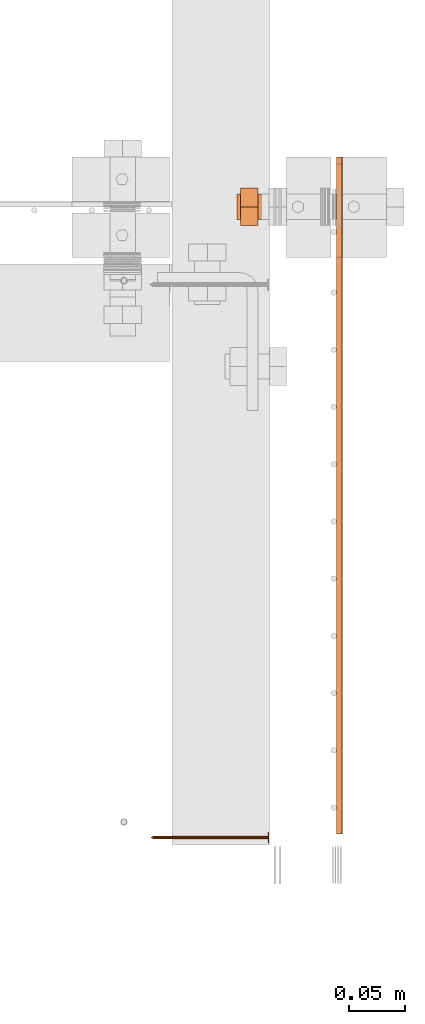
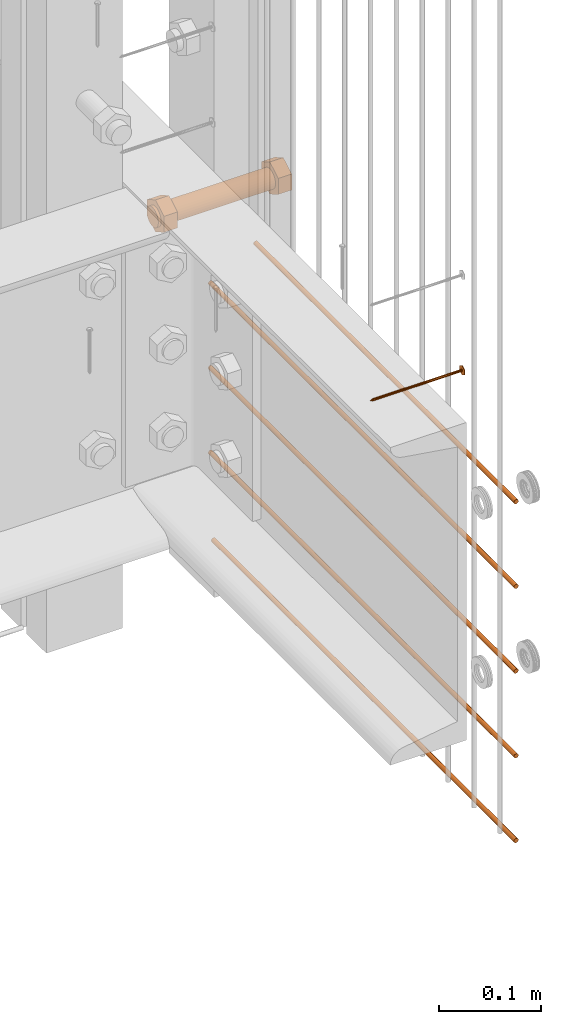
# One storey, part 21 of 44: 7 proxies.
"""IFC4 building model written with IfcOpenShell, lengths in feet."""

from ifc_helpers import new_model, entity, si_unit, converted_unit, derived_unit, direction, frame, frame_2d, origin, origin_2d_with_axis, place, context, subcontext, project, spatial, polyline, circle, outline, extrude, source, transform, mapped, material, type_object, type_shapes, element, save


model = new_model("IFC4")

# Units and contexts
model_context = context("Model", 3, precision=0.0001, world=origin(), true_north=direction((6.12303176911189e-17, 1.0)))
body_context = subcontext(model_context, "Body", "Model", "MODEL_VIEW")
ifc_project = project(units=[converted_unit("LENGTHUNIT", "FOOT", entity("IfcRatioMeasure", 0.3048), si_unit("LENGTHUNIT", "METRE"), dimensions=[1, 0, 0, 0, 0, 0, 0]), converted_unit("AREAUNIT", "SQUARE FOOT", entity("IfcRatioMeasure", 0.09290304), si_unit("AREAUNIT", "SQUARE_METRE"), dimensions=[2, 0, 0, 0, 0, 0, 0]), converted_unit("VOLUMEUNIT", "CUBIC FOOT", entity("IfcRatioMeasure", 0.028316846592), si_unit("VOLUMEUNIT", "CUBIC_METRE"), dimensions=[3, 0, 0, 0, 0, 0, 0]), converted_unit("PLANEANGLEUNIT", "DEGREE", entity("IfcRatioMeasure", 0.0174532925199433), si_unit("PLANEANGLEUNIT", "RADIAN"), dimensions=[0, 0, 0, 0, 0, 0, 0]), si_unit("MASSUNIT", "GRAM", prefix="KILO"), derived_unit("MASSDENSITYUNIT", [(si_unit("MASSUNIT", "GRAM", prefix="KILO"), 1), (si_unit("LENGTHUNIT", "METRE"), -3)]), derived_unit("MOMENTOFINERTIAUNIT", [(si_unit("LENGTHUNIT", "METRE"), 4)]), si_unit("TIMEUNIT", "SECOND"), si_unit("FREQUENCYUNIT", "HERTZ"), si_unit("THERMODYNAMICTEMPERATUREUNIT", "DEGREE_CELSIUS"), derived_unit("THERMALTRANSMITTANCEUNIT", [(si_unit("MASSUNIT", "GRAM", prefix="KILO"), 1), (si_unit("THERMODYNAMICTEMPERATUREUNIT", "KELVIN"), -1), (si_unit("TIMEUNIT", "SECOND"), -3)]), derived_unit("VOLUMETRICFLOWRATEUNIT", [(si_unit("LENGTHUNIT", "METRE"), 3), (si_unit("TIMEUNIT", "SECOND"), -1)]), si_unit("ELECTRICCURRENTUNIT", "AMPERE"), si_unit("ELECTRICVOLTAGEUNIT", "VOLT"), si_unit("POWERUNIT", "WATT"), si_unit("FORCEUNIT", "NEWTON"), si_unit("ILLUMINANCEUNIT", "LUX"), si_unit("LUMINOUSFLUXUNIT", "LUMEN"), si_unit("LUMINOUSINTENSITYUNIT", "CANDELA"), derived_unit("USERDEFINED", [(si_unit("MASSUNIT", "GRAM", prefix="KILO"), -1), (si_unit("LENGTHUNIT", "METRE"), -2), (si_unit("TIMEUNIT", "SECOND"), 3), (si_unit("LUMINOUSFLUXUNIT", "LUMEN"), 1)]), derived_unit("LINEARVELOCITYUNIT", [(si_unit("LENGTHUNIT", "METRE"), 1), (si_unit("TIMEUNIT", "SECOND"), -1)]), si_unit("PRESSUREUNIT", "PASCAL"), derived_unit("USERDEFINED", [(si_unit("LENGTHUNIT", "METRE"), -2), (si_unit("MASSUNIT", "GRAM", prefix="KILO"), 1), (si_unit("TIMEUNIT", "SECOND"), -2)]), derived_unit("LINEARFORCEUNIT", [(si_unit("MASSUNIT", "GRAM", prefix="KILO"), 1), (si_unit("LENGTHUNIT", "METRE"), 1), (si_unit("TIMEUNIT", "SECOND"), -2), (si_unit("LENGTHUNIT", "METRE"), -1)]), derived_unit("PLANARFORCEUNIT", [(si_unit("MASSUNIT", "GRAM", prefix="KILO"), 1), (si_unit("LENGTHUNIT", "METRE"), 1), (si_unit("TIMEUNIT", "SECOND"), -2), (si_unit("LENGTHUNIT", "METRE"), -2)])], contexts=[model_context])

# Site, building, storey
site_placement = place(None, origin())
site = spatial("IfcSite", under=ifc_project, at=site_placement, CompositionType="ELEMENT")
building_placement = place(site_placement, origin())
building = spatial("IfcBuilding", under=site, at=building_placement, CompositionType="ELEMENT")
storey_placement = place(building_placement, origin())
storey = spatial("IfcBuildingStorey", under=building, at=storey_placement, CompositionType="ELEMENT", Elevation=0.0)

# Proxies
ifc_material_1 = material(Category="Materials")
building_element_proxy_type_1 = type_object("IfcBuildingElementProxyType", Name="RAILING 14:RAILING 3", PredefinedType="NOTDEFINED", material=ifc_material_1)
shared_shape_1 = source(origin(), body_context, "Body", "SweptSolid", [
    extrude(circle(Radius=0.00833333333333333, at=origin_2d_with_axis()), frame((0.013567166128496, 0.0, 0.0135671661283361), z_axis=(0.0, 1.0, 0.0), x_axis=(1.0, 0.0, 0.0)), (0.0, 0.0, 1.0), 1.67905011872063),
])
type_shapes(building_element_proxy_type_1, [shared_shape_1])
proxy_1_placement = place(storey_placement, frame((1494.48288887973, 3.07882213648387, 9.50518283387163)))
element("IfcBuildingElementProxy", 1, at=proxy_1_placement, inside=storey, type_object=building_element_proxy_type_1, material=ifc_material_1, Name="RAILING 14:RAILING 3", ObjectType="RAILING 14:RAILING 3", PredefinedType="NOTDEFINED", context=body_context, shape_type="MappedRepresentation", body=[
    mapped(shared_shape_1, transform((0.0, 0.0, 0.0), scale=1.0)),
])
building_element_proxy_type_2 = type_object("IfcBuildingElementProxyType", Name="RAILING 15:RAILING 3", PredefinedType="NOTDEFINED", material=ifc_material_1)
shared_shape_2 = source(origin(), body_context, "Body", "SweptSolid", [
    extrude(circle(Radius=0.00833333333333333, at=origin_2d_with_axis()), frame((0.013567166128496, 0.0, 0.0135671661283361), z_axis=(0.0, 1.0, 0.0), x_axis=(1.0, 0.0, 0.0)), (0.0, 0.0, 1.0), 1.97071678538729),
])
type_shapes(building_element_proxy_type_2, [shared_shape_2])
proxy_2_placement = place(storey_placement, frame((1494.48288887973, 3.07882213648387, 9.1718495005383)))
element("IfcBuildingElementProxy", 2, at=proxy_2_placement, inside=storey, type_object=building_element_proxy_type_2, material=ifc_material_1, Name="RAILING 15:RAILING 3", ObjectType="RAILING 15:RAILING 3", PredefinedType="NOTDEFINED", context=body_context, shape_type="MappedRepresentation", body=[
    mapped(shared_shape_2, transform((0.0, 0.0, 0.0), scale=1.0)),
])
building_element_proxy_type_3 = type_object("IfcBuildingElementProxyType", Name="RAILING 16:RAILING 3", PredefinedType="NOTDEFINED", material=ifc_material_1)
shared_shape_3 = source(origin(), body_context, "Body", "SweptSolid", [
    extrude(circle(Radius=0.00833333333333333, at=origin_2d_with_axis()), frame((0.013567166128496, 0.0, 0.0135671661283361), z_axis=(0.0, 1.0, 0.0), x_axis=(1.0, 0.0, 0.0)), (0.0, 0.0, 1.0), 1.97071678538729),
])
type_shapes(building_element_proxy_type_3, [shared_shape_3])
proxy_3_placement = place(storey_placement, frame((1494.48288887973, 3.07882213648387, 8.83851616720496)))
element("IfcBuildingElementProxy", 3, at=proxy_3_placement, inside=storey, type_object=building_element_proxy_type_3, material=ifc_material_1, Name="RAILING 16:RAILING 3", ObjectType="RAILING 16:RAILING 3", PredefinedType="NOTDEFINED", context=body_context, shape_type="MappedRepresentation", body=[
    mapped(shared_shape_3, transform((0.0, 0.0, 0.0), scale=1.0)),
])
building_element_proxy_type_4 = type_object("IfcBuildingElementProxyType", Name="RAILING 17:RAILING 3", PredefinedType="NOTDEFINED", material=ifc_material_1)
shared_shape_4 = source(origin(), body_context, "Body", "SweptSolid", [
    extrude(circle(Radius=0.00833333333333333, at=origin_2d_with_axis()), frame((0.013567166128496, 0.0, 0.0135671661283361), z_axis=(0.0, 1.0, 0.0), x_axis=(1.0, 0.0, 0.0)), (0.0, 0.0, 1.0), 1.97071678538729),
])
type_shapes(building_element_proxy_type_4, [shared_shape_4])
proxy_4_placement = place(storey_placement, frame((1494.48288887973, 3.07882213648387, 8.50518283387163)))
element("IfcBuildingElementProxy", 4, at=proxy_4_placement, inside=storey, type_object=building_element_proxy_type_4, material=ifc_material_1, Name="RAILING 17:RAILING 3", ObjectType="RAILING 17:RAILING 3", PredefinedType="NOTDEFINED", context=body_context, shape_type="MappedRepresentation", body=[
    mapped(shared_shape_4, transform((0.0, 0.0, 0.0), scale=1.0)),
])
building_element_proxy_type_5 = type_object("IfcBuildingElementProxyType", Name="RAILING 18:RAILING 3", PredefinedType="NOTDEFINED", material=ifc_material_1)
shared_shape_5 = source(origin(), body_context, "Body", "SweptSolid", [
    extrude(circle(Radius=0.00833333333333333, at=origin_2d_with_axis()), frame((0.013567166128496, 0.0, 0.0135671661283361), z_axis=(0.0, 1.0, 0.0), x_axis=(1.0, 0.0, 0.0)), (0.0, 0.0, 1.0), 1.95121927353794),
])
type_shapes(building_element_proxy_type_5, [shared_shape_5])
proxy_5_placement = place(storey_placement, frame((1494.48288887973, 3.07882213648387, 8.1718495005383)))
element("IfcBuildingElementProxy", 5, at=proxy_5_placement, inside=storey, type_object=building_element_proxy_type_5, material=ifc_material_1, Name="RAILING 18:RAILING 3", ObjectType="RAILING 18:RAILING 3", PredefinedType="NOTDEFINED", context=body_context, shape_type="MappedRepresentation", body=[
    mapped(shared_shape_5, transform((0.0, 0.0, 0.0), scale=1.0)),
])
ifc_material_2 = material(Name="TRIM HEAD SCREWS AT RAILING - EXTERIOR GRADE", Category="Materials")
building_element_proxy_type_6 = type_object("IfcBuildingElementProxyType", PredefinedType="NOTDEFINED", material=ifc_material_2)
cartesian_point_1 = entity("IfcCartesianPoint", [0.0, 0.00455729166677942, -0.333333333333231])
vertex_point_1 = entity("IfcVertexPoint", cartesian_point_1)
cartesian_point_2 = entity("IfcCartesianPoint", [0.0, 0.0, -0.333333333333232])
vertex_point_2 = entity("IfcVertexPoint", cartesian_point_2)
ifc_direction_1 = entity("IfcDirection", [0.0, -1.0, 0.0])
edge_curve_1 = entity("IfcEdgeCurve", vertex_point_1, vertex_point_2, entity("IfcTrimmedCurve", entity("IfcLine", cartesian_point_1, entity("IfcVector", ifc_direction_1, 1.0)), [cartesian_point_1], [cartesian_point_2], True, "CARTESIAN"), True)
cartesian_point_3 = entity("IfcCartesianPoint", [0.0, -0.00455729166667798, -0.333333333333232])
vertex_point_3 = entity("IfcVertexPoint", cartesian_point_3)
edge_curve_2 = entity("IfcEdgeCurve", vertex_point_2, vertex_point_3, entity("IfcTrimmedCurve", entity("IfcLine", cartesian_point_2, entity("IfcVector", ifc_direction_1, 1.0)), [cartesian_point_2], [cartesian_point_3], True, "CARTESIAN"), True)
ifc_direction_2 = entity("IfcDirection", [0.0, 0.0, 1.0])
edge_curve_3 = entity("IfcEdgeCurve", vertex_point_3, vertex_point_1, entity("IfcTrimmedCurve", entity("IfcCircle", entity("IfcAxis2Placement3D", cartesian_point_2, ifc_direction_2, ifc_direction_1), 0.0045572916667287), [cartesian_point_3], [cartesian_point_1], True, "CARTESIAN"), True)
edge_curve_4 = entity("IfcEdgeCurve", vertex_point_1, vertex_point_3, entity("IfcTrimmedCurve", entity("IfcCircle", entity("IfcAxis2Placement3D", cartesian_point_2, ifc_direction_2, ifc_direction_1), 0.0045572916667287), [cartesian_point_1], [cartesian_point_3], True, "CARTESIAN"), True)
cartesian_point_4 = entity("IfcCartesianPoint", [0.0, 0.0, -0.342447916666333])
vertex_point_4 = entity("IfcVertexPoint", cartesian_point_4)
edge_curve_5 = entity("IfcEdgeCurve", vertex_point_4, vertex_point_1, entity("IfcTrimmedCurve", entity("IfcLine", cartesian_point_4, entity("IfcVector", entity("IfcDirection", [0.0, 0.447213595514579, 0.894427190992605]), 1.0)), [cartesian_point_4], [cartesian_point_1], True, "CARTESIAN"), True)
edge_curve_6 = entity("IfcEdgeCurve", vertex_point_3, vertex_point_4, entity("IfcTrimmedCurve", entity("IfcLine", cartesian_point_3, entity("IfcVector", entity("IfcDirection", [0.0, 0.447213595514596, -0.894427190992597]), 1.0)), [cartesian_point_3], [cartesian_point_4], True, "CARTESIAN"), True)
cartesian_point_5 = entity("IfcCartesianPoint", [-0.00455729166669724, 0.0, -0.333333333333231])
cartesian_point_6 = entity("IfcCartesianPoint", [0.0, 0.0, -0.338202184590857])
ifc_direction_3 = entity("IfcDirection", [0.0, 0.0, -1.0])
cartesian_point_7 = entity("IfcCartesianPoint", [-0.0156249999999625, -0.00902109795594613, 0.00260416666704037])
vertex_point_5 = entity("IfcVertexPoint", cartesian_point_7)
cartesian_point_8 = entity("IfcCartesianPoint", [0.0, -0.0180421959120243, 0.00260416666704032])
vertex_point_6 = entity("IfcVertexPoint", cartesian_point_8)
edge_curve_7 = entity("IfcEdgeCurve", vertex_point_5, vertex_point_6, entity("IfcTrimmedCurve", entity("IfcLine", cartesian_point_7, entity("IfcVector", entity("IfcDirection", [0.866025403784438, -0.500000000000001, 0.0]), 1.0)), [cartesian_point_7], [cartesian_point_8], True, "CARTESIAN"), True)
cartesian_point_9 = entity("IfcCartesianPoint", [0.0156250000000786, -0.00902109795590273, 0.00260416666704037])
vertex_point_7 = entity("IfcVertexPoint", cartesian_point_9)
edge_curve_8 = entity("IfcEdgeCurve", vertex_point_6, vertex_point_7, entity("IfcTrimmedCurve", entity("IfcLine", cartesian_point_8, entity("IfcVector", entity("IfcDirection", [0.866025403784437, 0.500000000000003, 0.0]), 1.0)), [cartesian_point_8], [cartesian_point_9], True, "CARTESIAN"), True)
cartesian_point_10 = entity("IfcCartesianPoint", [0.0156250000000786, 0.00902109795620598, 0.00260416666704046])
vertex_point_8 = entity("IfcVertexPoint", cartesian_point_10)
ifc_direction_4 = entity("IfcDirection", [0.0, 1.0, 0.0])
edge_curve_9 = entity("IfcEdgeCurve", vertex_point_7, vertex_point_8, entity("IfcTrimmedCurve", entity("IfcLine", cartesian_point_9, entity("IfcVector", ifc_direction_4, 1.0)), [cartesian_point_9], [cartesian_point_10], True, "CARTESIAN"), True)
cartesian_point_11 = entity("IfcCartesianPoint", [0.0, 0.0180421959123274, 0.0026041666670405])
vertex_point_9 = entity("IfcVertexPoint", cartesian_point_11)
edge_curve_10 = entity("IfcEdgeCurve", vertex_point_8, vertex_point_9, entity("IfcTrimmedCurve", entity("IfcLine", cartesian_point_10, entity("IfcVector", entity("IfcDirection", [-0.86602540378444, 0.499999999999998, 0.0]), 1.0)), [cartesian_point_10], [cartesian_point_11], True, "CARTESIAN"), True)
cartesian_point_12 = entity("IfcCartesianPoint", [-0.0156249999999625, 0.0090210979562493, 0.00260416666704046])
vertex_point_10 = entity("IfcVertexPoint", cartesian_point_12)
edge_curve_11 = entity("IfcEdgeCurve", vertex_point_9, vertex_point_10, entity("IfcTrimmedCurve", entity("IfcLine", cartesian_point_11, entity("IfcVector", entity("IfcDirection", [-0.866025403784438, -0.500000000000001, 0.0]), 1.0)), [cartesian_point_11], [cartesian_point_12], True, "CARTESIAN"), True)
ifc_direction_5 = entity("IfcDirection", [0.0, -1.0, 0.0])
edge_curve_12 = entity("IfcEdgeCurve", vertex_point_10, vertex_point_5, entity("IfcTrimmedCurve", entity("IfcLine", cartesian_point_12, entity("IfcVector", ifc_direction_5, 1.0)), [cartesian_point_12], [cartesian_point_7], True, "CARTESIAN"), True)
ifc_direction_6 = entity("IfcDirection", [0.0, 0.0, 1.0])
cartesian_point_13 = entity("IfcCartesianPoint", [-0.0156249999999625, -0.00902109795594612, 0.0])
vertex_point_11 = entity("IfcVertexPoint", cartesian_point_13)
cartesian_point_14 = entity("IfcCartesianPoint", [-0.0156249999999625, 0.00902109795624931, 0.0])
vertex_point_12 = entity("IfcVertexPoint", cartesian_point_14)
edge_curve_13 = entity("IfcEdgeCurve", vertex_point_11, vertex_point_12, entity("IfcTrimmedCurve", entity("IfcLine", cartesian_point_13, entity("IfcVector", ifc_direction_4, 1.0)), [cartesian_point_13], [cartesian_point_14], True, "CARTESIAN"), True)
cartesian_point_15 = entity("IfcCartesianPoint", [0.0, 0.0180421959123274, 0.0])
vertex_point_13 = entity("IfcVertexPoint", cartesian_point_15)
edge_curve_14 = entity("IfcEdgeCurve", vertex_point_12, vertex_point_13, entity("IfcTrimmedCurve", entity("IfcLine", cartesian_point_14, entity("IfcVector", entity("IfcDirection", [0.866025403784438, 0.500000000000001, 0.0]), 1.0)), [cartesian_point_14], [cartesian_point_15], True, "CARTESIAN"), True)
cartesian_point_16 = entity("IfcCartesianPoint", [0.0156250000000786, 0.00902109795620599, 0.0])
vertex_point_14 = entity("IfcVertexPoint", cartesian_point_16)
edge_curve_15 = entity("IfcEdgeCurve", vertex_point_13, vertex_point_14, entity("IfcTrimmedCurve", entity("IfcLine", cartesian_point_15, entity("IfcVector", entity("IfcDirection", [0.86602540378444, -0.499999999999998, 0.0]), 1.0)), [cartesian_point_15], [cartesian_point_16], True, "CARTESIAN"), True)
cartesian_point_17 = entity("IfcCartesianPoint", [0.0156250000000786, -0.00902109795590272, 0.0])
vertex_point_15 = entity("IfcVertexPoint", cartesian_point_17)
edge_curve_16 = entity("IfcEdgeCurve", vertex_point_14, vertex_point_15, entity("IfcTrimmedCurve", entity("IfcLine", cartesian_point_16, entity("IfcVector", ifc_direction_5, 1.0)), [cartesian_point_16], [cartesian_point_17], True, "CARTESIAN"), True)
cartesian_point_18 = entity("IfcCartesianPoint", [0.0, -0.0180421959120242, 0.0])
vertex_point_16 = entity("IfcVertexPoint", cartesian_point_18)
edge_curve_17 = entity("IfcEdgeCurve", vertex_point_15, vertex_point_16, entity("IfcTrimmedCurve", entity("IfcLine", cartesian_point_17, entity("IfcVector", entity("IfcDirection", [-0.866025403784437, -0.500000000000003, 0.0]), 1.0)), [cartesian_point_17], [cartesian_point_18], True, "CARTESIAN"), True)
edge_curve_18 = entity("IfcEdgeCurve", vertex_point_16, vertex_point_11, entity("IfcTrimmedCurve", entity("IfcLine", cartesian_point_18, entity("IfcVector", entity("IfcDirection", [-0.866025403784438, 0.500000000000001, 0.0]), 1.0)), [cartesian_point_18], [cartesian_point_13], True, "CARTESIAN"), True)
ifc_direction_7 = entity("IfcDirection", [0.0, 0.0, -1.0])
edge_curve_19 = entity("IfcEdgeCurve", vertex_point_10, vertex_point_12, entity("IfcTrimmedCurve", entity("IfcLine", cartesian_point_14, entity("IfcVector", ifc_direction_7, 1.0)), [cartesian_point_12], [cartesian_point_14], True, "CARTESIAN"), True)
edge_curve_20 = entity("IfcEdgeCurve", vertex_point_11, vertex_point_5, entity("IfcTrimmedCurve", entity("IfcLine", cartesian_point_13, entity("IfcVector", ifc_direction_6, 1.0)), [cartesian_point_13], [cartesian_point_7], True, "CARTESIAN"), True)
edge_curve_21 = entity("IfcEdgeCurve", vertex_point_9, vertex_point_13, entity("IfcTrimmedCurve", entity("IfcLine", cartesian_point_15, entity("IfcVector", ifc_direction_7, 1.0)), [cartesian_point_11], [cartesian_point_15], True, "CARTESIAN"), True)
edge_curve_22 = entity("IfcEdgeCurve", vertex_point_8, vertex_point_14, entity("IfcTrimmedCurve", entity("IfcLine", cartesian_point_16, entity("IfcVector", ifc_direction_7, 1.0)), [cartesian_point_10], [cartesian_point_16], True, "CARTESIAN"), True)
edge_curve_23 = entity("IfcEdgeCurve", vertex_point_7, vertex_point_15, entity("IfcTrimmedCurve", entity("IfcLine", cartesian_point_17, entity("IfcVector", ifc_direction_7, 1.0)), [cartesian_point_9], [cartesian_point_17], True, "CARTESIAN"), True)
edge_curve_24 = entity("IfcEdgeCurve", vertex_point_6, vertex_point_16, entity("IfcTrimmedCurve", entity("IfcLine", cartesian_point_18, entity("IfcVector", ifc_direction_7, 1.0)), [cartesian_point_8], [cartesian_point_18], True, "CARTESIAN"), True)
cartesian_point_19 = entity("IfcCartesianPoint", [0.0, 0.00455729166682102, 0.0])
vertex_point_17 = entity("IfcVertexPoint", cartesian_point_19)
cartesian_point_20 = entity("IfcCartesianPoint", [0.0, -0.00455729166651231, 0.0])
vertex_point_18 = entity("IfcVertexPoint", cartesian_point_20)
cartesian_point_21 = entity("IfcCartesianPoint", [0.0, 0.0, 0.0])
ifc_direction_8 = entity("IfcDirection", [0.0, 0.0, 1.0])
ifc_direction_9 = entity("IfcDirection", [0.0, -1.0, 0.0])
edge_curve_25 = entity("IfcEdgeCurve", vertex_point_17, vertex_point_18, entity("IfcTrimmedCurve", entity("IfcCircle", entity("IfcAxis2Placement3D", cartesian_point_21, ifc_direction_8, ifc_direction_9), 0.00455729166666667), [cartesian_point_19], [cartesian_point_20], True, "CARTESIAN"), True)
edge_curve_26 = entity("IfcEdgeCurve", vertex_point_18, vertex_point_17, entity("IfcTrimmedCurve", entity("IfcCircle", entity("IfcAxis2Placement3D", cartesian_point_21, ifc_direction_8, ifc_direction_9), 0.00455729166666667), [cartesian_point_20], [cartesian_point_19], True, "CARTESIAN"), True)
cartesian_point_22 = entity("IfcCartesianPoint", [0.0, 0.00455729166682389, -0.333333333333339])
vertex_point_19 = entity("IfcVertexPoint", cartesian_point_22)
cartesian_point_23 = entity("IfcCartesianPoint", [0.0, -0.00455729166650944, -0.333333333333339])
vertex_point_20 = entity("IfcVertexPoint", cartesian_point_23)
cartesian_point_24 = entity("IfcCartesianPoint", [0.0, 0.0, -0.333333333333339])
ifc_direction_10 = entity("IfcDirection", [0.0, 0.0, -1.0])
edge_curve_27 = entity("IfcEdgeCurve", vertex_point_19, vertex_point_20, entity("IfcTrimmedCurve", entity("IfcCircle", entity("IfcAxis2Placement3D", cartesian_point_24, ifc_direction_10, ifc_direction_9), 0.00455729166666667), [cartesian_point_22], [cartesian_point_23], True, "CARTESIAN"), True)
edge_curve_28 = entity("IfcEdgeCurve", vertex_point_20, vertex_point_19, entity("IfcTrimmedCurve", entity("IfcCircle", entity("IfcAxis2Placement3D", cartesian_point_24, ifc_direction_10, ifc_direction_9), 0.00455729166666667), [cartesian_point_23], [cartesian_point_22], True, "CARTESIAN"), True)
edge_curve_29 = entity("IfcEdgeCurve", vertex_point_18, vertex_point_20, entity("IfcTrimmedCurve", entity("IfcLine", cartesian_point_23, entity("IfcVector", ifc_direction_10, 1.0)), [cartesian_point_20], [cartesian_point_23], True, "CARTESIAN"), True)
edge_curve_30 = entity("IfcEdgeCurve", vertex_point_19, vertex_point_17, entity("IfcTrimmedCurve", entity("IfcLine", cartesian_point_22, entity("IfcVector", ifc_direction_8, 1.0)), [cartesian_point_22], [cartesian_point_19], True, "CARTESIAN"), True)
shared_shape_6 = source(origin(), body_context, "Body", "AdvancedBrep", [
    entity("IfcAdvancedBrep", entity("IfcClosedShell", [entity("IfcAdvancedFace", [entity("IfcFaceOuterBound", entity("IfcEdgeLoop", [entity("IfcOrientedEdge", None, None, edge_curve_1, True), entity("IfcOrientedEdge", None, None, edge_curve_2, True), entity("IfcOrientedEdge", None, None, edge_curve_3, True)]), True)], entity("IfcPlane", entity("IfcAxis2Placement3D", cartesian_point_2, ifc_direction_2, ifc_direction_1)), True), entity("IfcAdvancedFace", [entity("IfcFaceOuterBound", entity("IfcEdgeLoop", [entity("IfcOrientedEdge", None, None, edge_curve_2, False), entity("IfcOrientedEdge", None, None, edge_curve_1, False), entity("IfcOrientedEdge", None, None, edge_curve_4, True)]), True)], entity("IfcPlane", entity("IfcAxis2Placement3D", cartesian_point_2, ifc_direction_2, ifc_direction_1)), True), entity("IfcAdvancedFace", [entity("IfcFaceOuterBound", entity("IfcEdgeLoop", [entity("IfcOrientedEdge", None, None, edge_curve_5, True), entity("IfcOrientedEdge", None, None, edge_curve_3, False), entity("IfcOrientedEdge", None, None, edge_curve_6, True)]), True)], entity("IfcSurfaceOfRevolution", entity("IfcArbitraryOpenProfileDef", "CURVE", None, entity("IfcTrimmedCurve", entity("IfcLine", cartesian_point_4, entity("IfcVector", entity("IfcDirection", [0.447213595514577, 0.0, -0.894427190992606]), 1.0)), [cartesian_point_5], [cartesian_point_4], True, "CARTESIAN")), None, entity("IfcAxis1Placement", cartesian_point_6, ifc_direction_3)), True), entity("IfcAdvancedFace", [entity("IfcFaceOuterBound", entity("IfcEdgeLoop", [entity("IfcOrientedEdge", None, None, edge_curve_6, False), entity("IfcOrientedEdge", None, None, edge_curve_4, False), entity("IfcOrientedEdge", None, None, edge_curve_5, False)]), True)], entity("IfcSurfaceOfRevolution", entity("IfcArbitraryOpenProfileDef", "CURVE", None, entity("IfcTrimmedCurve", entity("IfcLine", cartesian_point_4, entity("IfcVector", entity("IfcDirection", [0.447213595514577, 0.0, -0.894427190992606]), 1.0)), [cartesian_point_5], [cartesian_point_4], True, "CARTESIAN")), None, entity("IfcAxis1Placement", cartesian_point_6, ifc_direction_3)), True)])),
    entity("IfcAdvancedBrep", entity("IfcClosedShell", [entity("IfcAdvancedFace", [entity("IfcFaceOuterBound", entity("IfcEdgeLoop", [entity("IfcOrientedEdge", None, None, edge_curve_7, True), entity("IfcOrientedEdge", None, None, edge_curve_8, True), entity("IfcOrientedEdge", None, None, edge_curve_9, True), entity("IfcOrientedEdge", None, None, edge_curve_10, True), entity("IfcOrientedEdge", None, None, edge_curve_11, True), entity("IfcOrientedEdge", None, None, edge_curve_12, True)]), True)], entity("IfcPlane", entity("IfcAxis2Placement3D", cartesian_point_7, ifc_direction_6, ifc_direction_4)), True), entity("IfcAdvancedFace", [entity("IfcFaceOuterBound", entity("IfcEdgeLoop", [entity("IfcOrientedEdge", None, None, edge_curve_13, True), entity("IfcOrientedEdge", None, None, edge_curve_14, True), entity("IfcOrientedEdge", None, None, edge_curve_15, True), entity("IfcOrientedEdge", None, None, edge_curve_16, True), entity("IfcOrientedEdge", None, None, edge_curve_17, True), entity("IfcOrientedEdge", None, None, edge_curve_18, True)]), True)], entity("IfcPlane", entity("IfcAxis2Placement3D", cartesian_point_13, ifc_direction_7, ifc_direction_5)), True), entity("IfcAdvancedFace", [entity("IfcFaceOuterBound", entity("IfcEdgeLoop", [entity("IfcOrientedEdge", None, None, edge_curve_19, True), entity("IfcOrientedEdge", None, None, edge_curve_13, False), entity("IfcOrientedEdge", None, None, edge_curve_20, True), entity("IfcOrientedEdge", None, None, edge_curve_12, False)]), True)], entity("IfcPlane", entity("IfcAxis2Placement3D", cartesian_point_7, entity("IfcDirection", [-1.0, 0.0, 0.0]), ifc_direction_7)), True), entity("IfcAdvancedFace", [entity("IfcFaceOuterBound", entity("IfcEdgeLoop", [entity("IfcOrientedEdge", None, None, edge_curve_21, True), entity("IfcOrientedEdge", None, None, edge_curve_14, False), entity("IfcOrientedEdge", None, None, edge_curve_19, False), entity("IfcOrientedEdge", None, None, edge_curve_11, False)]), True)], entity("IfcPlane", entity("IfcAxis2Placement3D", cartesian_point_12, entity("IfcDirection", [-0.500000000000001, 0.866025403784438, 0.0]), ifc_direction_7)), True), entity("IfcAdvancedFace", [entity("IfcFaceOuterBound", entity("IfcEdgeLoop", [entity("IfcOrientedEdge", None, None, edge_curve_22, True), entity("IfcOrientedEdge", None, None, edge_curve_15, False), entity("IfcOrientedEdge", None, None, edge_curve_21, False), entity("IfcOrientedEdge", None, None, edge_curve_10, False)]), True)], entity("IfcPlane", entity("IfcAxis2Placement3D", cartesian_point_11, entity("IfcDirection", [0.499999999999998, 0.86602540378444, 0.0]), ifc_direction_7)), True), entity("IfcAdvancedFace", [entity("IfcFaceOuterBound", entity("IfcEdgeLoop", [entity("IfcOrientedEdge", None, None, edge_curve_23, True), entity("IfcOrientedEdge", None, None, edge_curve_16, False), entity("IfcOrientedEdge", None, None, edge_curve_22, False), entity("IfcOrientedEdge", None, None, edge_curve_9, False)]), True)], entity("IfcPlane", entity("IfcAxis2Placement3D", cartesian_point_10, entity("IfcDirection", [1.0, 0.0, 0.0]), ifc_direction_7)), True), entity("IfcAdvancedFace", [entity("IfcFaceOuterBound", entity("IfcEdgeLoop", [entity("IfcOrientedEdge", None, None, edge_curve_24, True), entity("IfcOrientedEdge", None, None, edge_curve_17, False), entity("IfcOrientedEdge", None, None, edge_curve_23, False), entity("IfcOrientedEdge", None, None, edge_curve_8, False)]), True)], entity("IfcPlane", entity("IfcAxis2Placement3D", cartesian_point_9, entity("IfcDirection", [0.500000000000003, -0.866025403784437, 0.0]), ifc_direction_7)), True), entity("IfcAdvancedFace", [entity("IfcFaceOuterBound", entity("IfcEdgeLoop", [entity("IfcOrientedEdge", None, None, edge_curve_20, False), entity("IfcOrientedEdge", None, None, edge_curve_18, False), entity("IfcOrientedEdge", None, None, edge_curve_24, False), entity("IfcOrientedEdge", None, None, edge_curve_7, False)]), True)], entity("IfcPlane", entity("IfcAxis2Placement3D", cartesian_point_8, entity("IfcDirection", [-0.500000000000001, -0.866025403784438, 0.0]), ifc_direction_7)), True)])),
    entity("IfcAdvancedBrep", entity("IfcClosedShell", [entity("IfcAdvancedFace", [entity("IfcFaceOuterBound", entity("IfcEdgeLoop", [entity("IfcOrientedEdge", None, None, edge_curve_25, True), entity("IfcOrientedEdge", None, None, edge_curve_26, True)]), True)], entity("IfcPlane", entity("IfcAxis2Placement3D", cartesian_point_20, ifc_direction_8, entity("IfcDirection", [-1.0, 0.0, 0.0]))), True), entity("IfcAdvancedFace", [entity("IfcFaceOuterBound", entity("IfcEdgeLoop", [entity("IfcOrientedEdge", None, None, edge_curve_27, True), entity("IfcOrientedEdge", None, None, edge_curve_28, True)]), True)], entity("IfcPlane", entity("IfcAxis2Placement3D", cartesian_point_23, ifc_direction_10, entity("IfcDirection", [1.0, 0.0, 0.0]))), True), entity("IfcAdvancedFace", [entity("IfcFaceOuterBound", entity("IfcEdgeLoop", [entity("IfcOrientedEdge", None, None, edge_curve_29, True), entity("IfcOrientedEdge", None, None, edge_curve_27, False), entity("IfcOrientedEdge", None, None, edge_curve_30, True), entity("IfcOrientedEdge", None, None, edge_curve_26, False)]), True)], entity("IfcCylindricalSurface", entity("IfcAxis2Placement3D", cartesian_point_24, ifc_direction_8, ifc_direction_9), 0.00455729166666667), True), entity("IfcAdvancedFace", [entity("IfcFaceOuterBound", entity("IfcEdgeLoop", [entity("IfcOrientedEdge", None, None, edge_curve_30, False), entity("IfcOrientedEdge", None, None, edge_curve_28, False), entity("IfcOrientedEdge", None, None, edge_curve_29, False), entity("IfcOrientedEdge", None, None, edge_curve_25, False)]), True)], entity("IfcCylindricalSurface", entity("IfcAxis2Placement3D", cartesian_point_24, ifc_direction_8, ifc_direction_9), 0.00455729166666667), True)])),
])
type_shapes(building_element_proxy_type_6, [shared_shape_6])
proxy_6_placement = place(storey_placement, frame((1494.28903417085, 3.06838356430316, 10.1148601647184), z_axis=(1.0, 0.0, 0.0), x_axis=(0.0, 1.0, 0.0)))
element("IfcBuildingElementProxy", 6, at=proxy_6_placement, inside=storey, type_object=building_element_proxy_type_6, material=ifc_material_2, PredefinedType="NOTDEFINED", context=body_context, shape_type="MappedRepresentation", body=[
    mapped(shared_shape_6, transform((0.0, 0.0, 0.0), scale=1.0)),
])
ifc_material_3 = material(Name="EXPOSED LAG BOLTS", Category="Materials")
building_element_proxy_type_7 = type_object("IfcBuildingElementProxyType", PredefinedType="NOTDEFINED", material=ifc_material_3)
shared_shape_7 = source(origin(), body_context, "Body", "SweptSolid", [
    extrude(outline(polyline([(-0.0315738428463097, -0.0546875000000126), (0.0315738428462861, -0.0546875000000126), (0.0631476856926272, 0.0), (0.0315738428463528, 0.0546874999999876), (-0.0315738428463294, 0.0546874999999873), (-0.0631476856926271, 0.0), (-0.0315738428463097, -0.0546875000000126)])), frame((0.0, 0.0, -0.425455729167055), z_axis=(0.0, 0.0, 1.0), x_axis=(0.866025403784438, -0.500000000000001, 0.0)), (0.0, 0.0, 1.0), 0.0504557291666657),
    extrude(outline(polyline([(-0.0315738428463175, -0.054687500000008), (0.0315738428463173, -0.054687500000008), (0.0631476856926152, 0.0), (0.0315738428462743, 0.0546875000000329), (-0.0315738428462739, 0.0546875000000332), (-0.0631476856926154, 0.0), (-0.0315738428463175, -0.054687500000008)])), frame((0.0, 0.0, 0.0), z_axis=(0.0, 0.0, 1.0), x_axis=(0.0, -1.0, 0.0)), (0.0, 0.0, 1.0), 0.0504557291666658),
    extrude(circle(Radius=0.0372721354166667, at=frame_2d((-3.16883874077982e-18, -6.0214796149918e-17), x_axis=(1.0, 0.0))), frame((0.0, 0.0, -0.436376009077554), z_axis=(0.0, 0.0, 1.0), x_axis=(0.0, 1.0, 0.0)), (0.0, 0.0, 1.0), 0.436376009077548),
])
type_shapes(building_element_proxy_type_7, [shared_shape_7])
proxy_7_placement = place(storey_placement, frame((1494.63395604586, 4.90491114741325, 9.63649652603837), z_axis=(1.0, 0.0, 0.0), x_axis=(0.0, 1.0, 0.0)))
element("IfcBuildingElementProxy", 7, at=proxy_7_placement, inside=storey, type_object=building_element_proxy_type_7, material=ifc_material_3, PredefinedType="NOTDEFINED", context=body_context, shape_type="MappedRepresentation", body=[
    mapped(shared_shape_7, transform((0.0, 0.0, 0.0), scale=1.0)),
])

save(model, "model.ifc")
